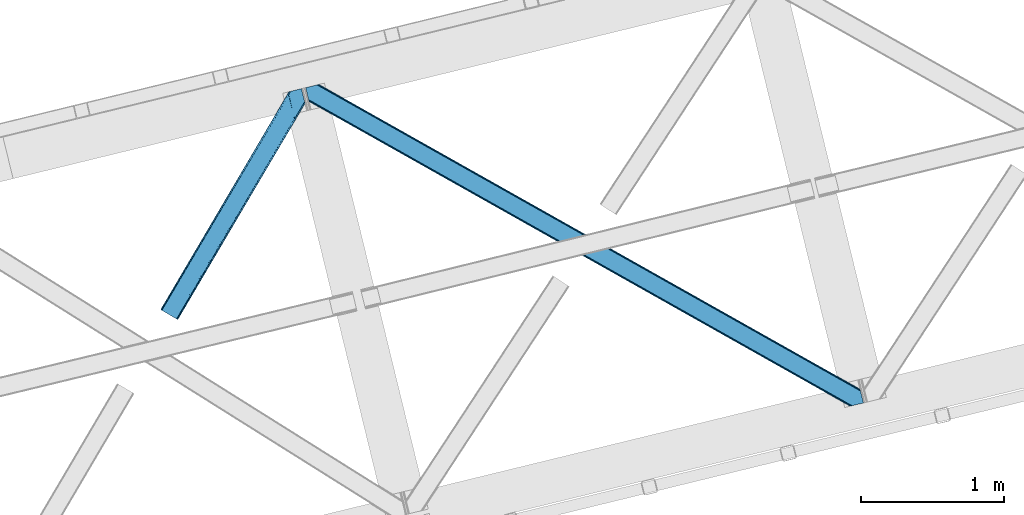
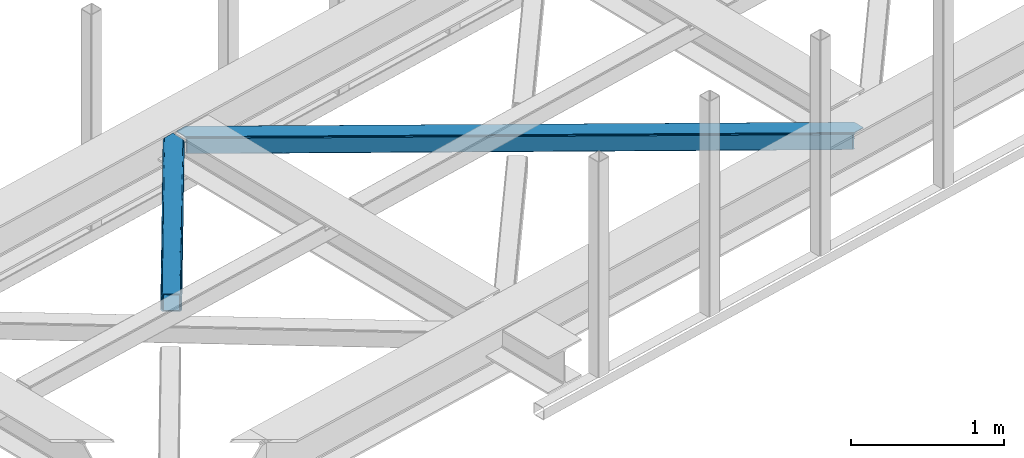
# One storey, part 26 of 67: 2 members.
"""IFC4 building model written with IfcOpenShell, lengths in millimetres."""

from ifc_helpers import new_model, entity, si_unit, converted_unit, derived_unit, direction, frame, origin, place, context, subcontext, project, spatial, triangles, type_object, element, save


model = new_model("IFC4")

# Units and contexts
model_context = context("Model", 3, precision=0.01, world=origin(), true_north=direction((6.12303176911189e-17, 1.0)))
plan_context = context("Plan", 3, precision=0.01, world=origin(), true_north=direction((6.12303176911189e-17, 1.0)))
body_context = subcontext(model_context, "Body", "Model", "MODEL_VIEW")
ifc_project = project(units=[si_unit("LENGTHUNIT", "METRE", prefix="MILLI"), si_unit("AREAUNIT", "SQUARE_METRE"), si_unit("VOLUMEUNIT", "CUBIC_METRE"), converted_unit("PLANEANGLEUNIT", "DEGREE", entity("IfcRatioMeasure", 0.0174532925199433), si_unit("PLANEANGLEUNIT", "RADIAN"), dimensions=[0, 0, 0, 0, 0, 0, 0]), si_unit("MASSUNIT", "GRAM", prefix="KILO"), derived_unit("MASSDENSITYUNIT", [(si_unit("MASSUNIT", "GRAM", prefix="KILO"), 1), (si_unit("LENGTHUNIT", "METRE"), -3)]), derived_unit("MOMENTOFINERTIAUNIT", [(si_unit("LENGTHUNIT", "METRE"), 4)]), si_unit("TIMEUNIT", "SECOND"), si_unit("FREQUENCYUNIT", "HERTZ"), si_unit("THERMODYNAMICTEMPERATUREUNIT", "DEGREE_CELSIUS"), derived_unit("THERMALTRANSMITTANCEUNIT", [(si_unit("MASSUNIT", "GRAM", prefix="KILO"), 1), (si_unit("THERMODYNAMICTEMPERATUREUNIT", "KELVIN"), -1), (si_unit("TIMEUNIT", "SECOND"), -3)]), derived_unit("VOLUMETRICFLOWRATEUNIT", [(si_unit("LENGTHUNIT", "METRE"), 3), (si_unit("TIMEUNIT", "SECOND"), -1)]), derived_unit("MASSFLOWRATEUNIT", [(si_unit("MASSUNIT", "GRAM", prefix="KILO"), 1), (si_unit("TIMEUNIT", "SECOND"), -1)]), derived_unit("ROTATIONALFREQUENCYUNIT", [(si_unit("TIMEUNIT", "SECOND"), -1)]), si_unit("ELECTRICCURRENTUNIT", "AMPERE"), si_unit("ELECTRICVOLTAGEUNIT", "VOLT"), si_unit("POWERUNIT", "WATT"), si_unit("FORCEUNIT", "NEWTON", prefix="KILO"), si_unit("ILLUMINANCEUNIT", "LUX"), si_unit("LUMINOUSFLUXUNIT", "LUMEN"), si_unit("LUMINOUSINTENSITYUNIT", "CANDELA"), derived_unit("USERDEFINED", [(si_unit("MASSUNIT", "GRAM", prefix="KILO"), -1), (si_unit("LENGTHUNIT", "METRE"), -2), (si_unit("TIMEUNIT", "SECOND"), 3), (si_unit("LUMINOUSFLUXUNIT", "LUMEN"), 1)]), derived_unit("LINEARVELOCITYUNIT", [(si_unit("LENGTHUNIT", "METRE"), 1), (si_unit("TIMEUNIT", "SECOND"), -1)]), si_unit("PRESSUREUNIT", "PASCAL"), derived_unit("USERDEFINED", [(si_unit("LENGTHUNIT", "METRE"), -2), (si_unit("MASSUNIT", "GRAM", prefix="KILO"), 1), (si_unit("TIMEUNIT", "SECOND"), -2)]), derived_unit("LINEARFORCEUNIT", [(si_unit("MASSUNIT", "GRAM", prefix="KILO"), 1), (si_unit("LENGTHUNIT", "METRE"), 1), (si_unit("TIMEUNIT", "SECOND"), -2), (si_unit("LENGTHUNIT", "METRE"), -1)]), derived_unit("PLANARFORCEUNIT", [(si_unit("MASSUNIT", "GRAM", prefix="KILO"), 1), (si_unit("LENGTHUNIT", "METRE"), 1), (si_unit("TIMEUNIT", "SECOND"), -2), (si_unit("LENGTHUNIT", "METRE"), -2)])], contexts=[model_context, plan_context])

# Site, building, storey
site_placement = place(None, origin())
site = spatial("IfcSite", under=ifc_project, at=site_placement, CompositionType="ELEMENT")
building_placement = place(site_placement, origin())
building = spatial("IfcBuilding", under=site, at=building_placement, CompositionType="ELEMENT")
storey_placement = place(building_placement, frame((0.0, 0.0, 19800.0)))
storey = spatial("IfcBuildingStorey", under=building, at=storey_placement, CompositionType="ELEMENT", Elevation=19800.0)

# Members
member_type_1 = type_object("IfcMemberType", PredefinedType="BRACE")
member_1_placement = place(storey_placement, frame((-49332.8771484375, 6520.94441070557, 3823.99987792968)))
element("IfcMember", 1, at=member_1_placement, inside=storey, type_object=member_type_1, ObjectType="Steel Horizontal Brace", PredefinedType="BRACE", context=body_context, shape_type="Tessellation", body=[
    triangles([(3809.33957519531, 0.0, 122.499499511719), (3811.23713378907, 0.462181091308594, 129.196765136719), (23.4590332031294, 2133.5476776123, 129.196765136719), (23.8915649414048, 2131.77569274902, 122.499499511719), (3816.63215332032, 1.7772171020506, 134.87548828125), (22.2265502929731, 2138.59446258545, 134.87548828125), (3824.70607910156, 3.74512023925763, 138.668280029298), (20.3894531250044, 2146.14690856934, 138.668280029298), (3834.23107910156, 6.06707153320258, 140.00075683594), (18.2174926757798, 2155.05566711426, 140.00075683594), (1916.9806640625, 1065.68146362305, 17.5012573242202), (2556.1183959961, 705.752851867675, 17.5012573242202), (3195.25147705078, 345.824240112304, 17.5012573242202), (3809.33957519531, 0.0, 17.5012573242202), (1277.84758300782, 1425.61065673828, 17.5012573242202), (638.709851074222, 1785.53868713379, 17.5012573242202), (23.8915649414048, 2131.77569274902, 17.5012573242202), (3885.46051025391, 97.721360778808, 140.00075683594), (3903.67800292969, 22.9951080322262, 140.00075683594), (69.4469238281235, 2246.70995635986, 140.00075683594), (0.0, 2229.78191986084, 140.00075683594), (3883.28854980469, 106.63011932373, 138.668280029298), (78.971923828125, 2249.03190765381, 138.668280029298), (3881.44680175781, 114.182565307617, 134.87548828125), (87.0458496093779, 2251.00039215088, 134.87548828125), (3880.21896972656, 119.229350280762, 129.196765136719), (92.4408691406279, 2252.31542816162, 129.196765136719), (3879.78643798828, 121.001335144043, 122.499499511719), (94.3384277343794, 2252.77760925293, 122.499499511719), (3265.41928710938, 466.982542419433, 17.5012573242202), (3879.78643798828, 121.001335144043, 17.5012573242202), (2626.2955078125, 826.905340576172, 17.5012573242202), (1987.17172851563, 1186.82813873291, 17.5012573242202), (708.924169921876, 1906.67315368652, 17.5012573242202), (94.3384277343794, 2252.77760925293, 17.5012573242202), (1348.04794921875, 1546.75093688965, 17.5012573242202), (77.0929687500029, 2248.57321472168, 127.873590087893), (69.0143920898481, 2246.60473022461, 131.668707275392), (82.4879882812529, 2249.88883209228, 122.197192382813), (59.4893920898467, 2244.28277893066, 133.001184082033), (0.0, 2229.78191986084, 133.001184082033), (84.3808959960952, 2250.35043182373, 115.499926757813), (84.3808959960952, 2250.35043182373, 24.5008300781265), (82.4879882812529, 2249.88883209228, 17.8035644531265), (92.0548461914077, 2252.22124786377, 10.8691040039084), (91.5851074218735, 2252.10613861084, 9.49942016601563), (77.0929687500029, 2248.57321472168, 12.1248413085959), (72.3118652343765, 2247.40816955566, 9.49942016601563), (1983.48823242188, 1180.86745605469, 24.5008300781265), (3882.05606689453, 111.689694213866, 115.499926757813), (2626.78850097657, 818.593057250976, 24.5008300781265), (3270.08876953125, 456.319239807129, 24.5008300781265), (3882.05606689453, 111.689694213866, 24.5008300781265), (1340.18796386719, 1543.14127349854, 24.5008300781265), (696.892346191409, 1905.41509094238, 24.5008300781265), (3882.48859863282, 109.917127990722, 122.197192382813), (3883.71643066406, 104.870924377441, 127.873590087893), (3885.55817871094, 97.318478393554, 131.668707275392), (3887.73013916016, 88.4097198486324, 133.001184082033), (3883.71643066406, 104.870924377441, 12.1248413085959), (3885.41865234375, 97.8998382568352, 8.52041015625218), (3880.59104003906, 117.702699279785, 8.52041015625218), (3903.67800292969, 22.9951080322262, 133.001184082033), (3882.48859863282, 109.917127990722, 17.8035644531265), (3880.37244873047, 118.590435791015, 10.9365417480476), (3844.18861083985, 8.4942489624018, 133.001184082033), (15.9478637695356, 2164.3678894043, 133.001184082033), (3834.66361083985, 6.17229766845685, 131.668707275392), (18.1198242187529, 2155.45854949951, 131.668707275392), (3826.58503417969, 4.20381317138617, 127.873590087893), (19.9569213867217, 2147.90610351563, 127.873590087893), (3821.19001464844, 2.88877716064417, 122.197192382813), (21.1894042968779, 2142.85989990234, 122.197192382813), (3819.2971069336, 2.42717742919922, 115.499926757813), (21.6219360351606, 2141.08791503906, 115.499926757813), (3208.50183105469, 346.39571685791, 24.5008300781265), (3819.2971069336, 2.42717742919922, 24.5008300781265), (2565.16435546875, 708.690463256836, 24.5008300781265), (1921.82687988281, 1070.98520965576, 24.5008300781265), (635.156579589842, 1795.57528381348, 24.5008300781265), (21.6219360351606, 2141.08791503906, 24.5008300781265), (1278.49405517578, 1433.28053741455, 24.5008300781265), (21.1894042968779, 2142.85989990234, 17.8035644531265), (19.9569213867217, 2147.90610351563, 12.1248413085959), (23.263696289061, 2134.3505355835, 9.49942016601563), (23.3706665039063, 2133.90986480713, 10.8691040039084), (18.8686157226548, 2152.37676086426, 9.49942016601563), (3821.19001464844, 2.88877716064417, 17.8035644531265), (3811.91616210937, 0.628450012206486, 10.9365417480476), (3812.86494140625, 0.859831237792605, 8.52041015625218), (3826.58503417969, 4.20381317138617, 12.1248413085959), (3834.04039306641, 6.02056274414008, 8.52041015625218), (190.667431640628, 2055.62743377685, 9.49942016601563), (195.062512207034, 2037.60120849609, 9.49942016601563), (196.076403808598, 2037.6692276001, 8.49948120117188), (196.057800292969, 2037.42389373779, 8.8831787109375), (191.290649414063, 2056.67097473144, 8.85294799804615), (195.732238769531, 2037.48144836426, 9.08316650390771), (191.346459960936, 2055.82567749023, 9.20641479492406), (195.388073730472, 2037.54365386963, 9.29943237304906), (191.006945800786, 2055.72684631348, 9.35291748046802), (191.239489746098, 2057.51627197266, 8.49948120117188), (150.921020507813, 2218.69073638916, 9.49942016601563), (155.316101074219, 2200.6645111084, 9.49942016601563), (151.251232910159, 2218.34947814941, 9.25757446289208), (155.813745117186, 2200.23721160889, 9.42500610351635), (151.60469970703, 2217.98496551514, 8.99945068359375), (156.250927734378, 2199.30529174805, 9.11804809570458), (151.962817382817, 2217.619871521, 8.74132690429906), (156.692761230472, 2198.36407012939, 8.80643920898365), (152.293029785156, 2217.27861328125, 8.49948120117188), (157.129943847656, 2197.43156890869, 8.49948120117188), (3713.61983642578, 194.649165344238, 8.52041015625218), (3708.7922241211, 214.452026367188, 8.52041015625218), (3713.26636962891, 194.529986572265, 8.40181274414135), (3708.39689941407, 214.570623779297, 8.37390747070458), (3713.06173095703, 194.460223388672, 8.3320495605476), (3708.00622558594, 214.689221191406, 8.22740478515698), (3707.90390625, 214.477606201172, 7.87393798828271), (3713.112890625, 193.949789428711, 8.19484863281468), (3707.80623779297, 214.265991210938, 7.52047119140843), (3713.23846435547, 192.705679321289, 7.85765991211156), (3713.36403808594, 191.465057373047, 7.52047119140843), (3264.76351318359, 465.821566772461, 10.8039916992202), (3262.90316162109, 462.516535949707, 5.12526855468968), (3260.11728515625, 457.569744873046, 1.33247680664135), (3708.58293457032, 211.088278198242, 5.59500732422021), (708.268395996092, 1905.51275939941, 10.8039916992202), (706.408044433592, 1902.2071472168, 5.12526855468968), (153.148791503911, 2213.77475738525, 5.12526855468968), (703.622167968751, 1897.26035614014, 1.33247680664135), (154.990539550781, 2206.22231140137, 1.33247680664135), (700.333996582034, 1891.42524719238, 0.0), (157.162499999999, 2197.31355285644, 0.0), (3710.29445800781, 204.051498413086, 1.33247680664135), (3712.46641845704, 195.142739868164, 0.0), (3256.83376464844, 451.73405456543, 0.0), (2625.63973388672, 825.744364929199, 10.8039916992202), (1986.51595458984, 1185.66716308594, 10.8039916992202), (1347.39217529297, 1545.58996124268, 10.8039916992202), (2623.77938232422, 822.439334106445, 5.12526855468968), (1984.65560302734, 1182.36213226318, 5.12526855468968), (1345.53182373047, 1542.28434906006, 5.12526855468968), (2620.99350585938, 817.492543029785, 1.33247680664135), (1981.8697265625, 1177.41475982666, 1.33247680664135), (1342.74594726563, 1537.3375579834, 1.33247680664135), (2617.70998535156, 811.656852722168, 0.0), (1978.58155517578, 1171.57965087891, 0.0), (1339.45777587891, 1531.50244903564, 0.0), (3746.51550292969, 55.4634750366204, 0.0), (3203.83699951172, 361.072146606445, 0.0), (2564.70391845703, 721.000758361816, 0.0), (1925.57083740235, 1080.92995147705, 0.0), (1286.43310546875, 1440.85856323242, 0.0), (647.300024414064, 1800.78717498779, 0.0), (191.206933593749, 2057.6342880249, 0.0), (3195.90725097656, 346.984634399414, 10.8039916992202), (639.365624999999, 1786.69966278076, 10.8039916992202), (641.225976562499, 1790.00527496338, 5.12526855468968), (195.220642089844, 2041.17308349609, 5.12526855468968), (3197.76760253906, 350.290246582031, 5.12526855468968), (3200.55347900391, 355.237037658691, 1.33247680664135), (3748.6874633789, 46.5547164916989, 1.33247680664135), (3752.58024902344, 34.8100845336912, 8.52041015625218), (3750.40363769532, 39.517936706543, 5.59500732422021), (3751.18033447266, 36.3402236938473, 7.52047119140843), (3752.24073486328, 35.1804107666012, 8.278564453125), (644.011853027347, 1794.95206604004, 1.33247680664135), (193.378894042973, 2048.72552947998, 1.33247680664135), (2561.41574707031, 715.165649414063, 1.33247680664135), (1922.28266601563, 1075.09426116943, 1.33247680664135), (1283.14958496094, 1435.02345428467, 1.33247680664135), (2558.62987060547, 710.218858337402, 5.12526855468968), (1919.49678955078, 1070.14747009277, 5.12526855468968), (1280.36370849609, 1430.07666320801, 5.12526855468968), (2556.76951904297, 706.913246154785, 10.8039916992202), (1917.63643798828, 1066.84243927002, 10.8039916992202), (1278.49870605469, 1426.77105102539, 10.8039916992202), (3745.61788330078, 59.1411575317379, 7.52047119140843), (3746.13413085938, 57.3430114746088, 7.90416870117406), (3746.6736328125, 56.4360900878901, 8.10880737304615), (3747.30150146485, 55.3762710571282, 8.34832763671875), (3747.75263671875, 54.6129455566406, 8.52041015625218), (3211.01795654297, 350.861723327636, 12.1248413085959), (3217.08735351563, 361.644204711914, 6.99957275390625), (3213.80383300781, 355.808514404296, 8.3320495605476), (3744.24587402344, 64.7751159667969, 6.99957275390625), (643.742102050783, 1810.82377166748, 6.99957275390625), (188.937304687504, 2066.94651031494, 6.99957275390625), (637.672705078126, 1800.0412902832, 12.1248413085959), (640.458581542967, 1804.98866271973, 8.3320495605476), (635.807702636717, 1796.73625946045, 17.8035644531265), (3209.15760498047, 347.556111145019, 17.8035644531265), (2565.82012939453, 709.851438903808, 17.8035644531265), (1922.4826538086, 1072.14618530273, 17.8035644531265), (1279.14517822266, 1434.44093170166, 17.8035644531265), (2567.68048095703, 713.156469726562, 12.1248413085959), (1924.3430053711, 1075.45179748535, 12.1248413085959), (1281.00552978516, 1437.74654388428, 12.1248413085959), (2570.46635742188, 718.103842163086, 8.3320495605476), (1927.12888183594, 1080.39858856201, 8.3320495605476), (1283.79140625, 1442.69333496094, 8.3320495605476), (2573.7545288086, 723.938951110839, 6.99957275390625), (1930.41705322266, 1086.23369750977, 6.99957275390625), (1287.07957763672, 1448.52902526855, 6.99957275390625), (694.376220703125, 1900.94908447266, 12.1248413085959), (691.590344238284, 1896.002293396, 8.3320495605476), (157.264819335942, 2196.88450927734, 8.41343994140698), (159.43212890625, 2188.00191192627, 6.99957275390625), (3261.50324707032, 441.070751953124, 6.99957275390625), (3264.78676757812, 446.905860900879, 8.3320495605476), (3714.73604736328, 185.831098937988, 6.99957275390625), (3267.57264404297, 451.853233337402, 12.1248413085959), (688.302172851567, 1890.16718444824, 6.99957275390625), (696.236572265625, 1904.25469665527, 17.8035644531265), (3269.43299560547, 455.158264160156, 17.8035644531265), (2618.20297851563, 803.344569396972, 6.99957275390625), (2621.48649902344, 809.179678344726, 8.3320495605476), (1978.18623046875, 1171.45407714844, 8.3320495605476), (1974.90270996094, 1165.61896820068, 6.99957275390625), (1334.89061279297, 1533.72847595215, 8.3320495605476), (1331.60244140625, 1527.89336700439, 6.99957275390625), (2624.27237548828, 814.12705078125, 12.1248413085959), (1980.9767578125, 1176.40144958496, 12.1248413085959), (1337.67648925781, 1538.67526702881, 12.1248413085959), (2626.13272705078, 817.432081604004, 17.8035644531265), (1982.837109375, 1179.70648040771, 17.8035644531265), (1339.53684082031, 1541.98087921143, 17.8035644531265)], [[1, 2, 3], [3, 4, 1], [2, 5, 6], [6, 3, 2], [5, 7, 8], [8, 6, 5], [7, 9, 10], [10, 8, 7], [11, 1, 4], [1, 12, 13], [11, 12, 1], [13, 14, 1], [15, 4, 16], [4, 15, 11], [17, 16, 4], [9, 18, 10], [9, 19, 18], [20, 10, 18], [21, 10, 20], [18, 22, 23], [23, 20, 18], [22, 24, 25], [25, 23, 22], [24, 26, 27], [27, 25, 24], [26, 28, 29], [29, 27, 26], [30, 28, 31], [28, 30, 32], [28, 33, 29], [33, 28, 32], [34, 35, 29], [36, 29, 33], [29, 36, 34], [37, 38, 23], [25, 37, 23], [25, 27, 39], [37, 25, 39], [39, 27, 29], [38, 20, 23], [21, 40, 41], [21, 20, 40], [38, 40, 20], [39, 29, 42], [43, 35, 44], [29, 43, 42], [35, 45, 44], [29, 35, 43], [46, 44, 45], [47, 44, 46], [48, 47, 46], [49, 50, 42], [50, 51, 52], [49, 51, 50], [52, 53, 50], [54, 42, 55], [42, 54, 49], [43, 55, 42], [50, 56, 42], [39, 42, 56], [56, 57, 39], [37, 39, 57], [57, 58, 37], [38, 37, 58], [58, 59, 38], [40, 38, 59], [57, 24, 22], [60, 61, 62], [24, 57, 56], [58, 57, 22], [58, 18, 59], [19, 59, 18], [59, 19, 63], [58, 22, 18], [31, 28, 53], [62, 64, 60], [64, 31, 53], [65, 64, 62], [65, 31, 64], [28, 50, 53], [56, 26, 24], [28, 26, 56], [50, 28, 56], [59, 66, 67], [66, 59, 63], [67, 40, 59], [41, 40, 67], [66, 68, 67], [69, 67, 68], [68, 70, 69], [71, 69, 70], [70, 72, 71], [73, 71, 72], [72, 74, 73], [75, 73, 74], [76, 74, 77], [74, 76, 78], [74, 79, 75], [79, 74, 78], [80, 81, 75], [82, 75, 79], [75, 82, 80], [73, 6, 71], [75, 81, 4], [3, 73, 4], [73, 3, 6], [73, 75, 4], [81, 17, 4], [83, 84, 85], [85, 86, 83], [86, 17, 83], [81, 83, 17], [67, 10, 21], [10, 69, 8], [69, 10, 67], [21, 41, 67], [69, 71, 8], [87, 85, 84], [8, 71, 6], [70, 68, 7], [5, 70, 7], [5, 2, 72], [70, 5, 72], [72, 2, 1], [68, 9, 7], [19, 66, 63], [19, 9, 66], [68, 66, 9], [72, 1, 74], [77, 14, 88], [1, 77, 74], [14, 89, 88], [1, 14, 77], [90, 88, 89], [91, 88, 90], [92, 91, 90], [93, 94, 85], [85, 87, 93], [95, 96, 97], [96, 98, 99], [99, 98, 100], [101, 100, 94], [94, 93, 101], [100, 101, 99], [99, 97, 96], [97, 102, 95], [103, 104, 46], [48, 46, 104], [105, 106, 104], [107, 108, 106], [109, 110, 108], [111, 112, 110], [110, 109, 111], [108, 107, 109], [106, 105, 107], [104, 103, 105], [62, 61, 113], [113, 114, 62], [115, 116, 114], [117, 118, 116], [116, 115, 117], [119, 118, 120], [121, 119, 122], [122, 123, 121], [120, 122, 119], [117, 120, 118], [114, 113, 115], [124, 30, 31], [125, 124, 118], [118, 119, 125], [119, 121, 125], [124, 65, 114], [114, 116, 124], [116, 118, 124], [65, 62, 114], [126, 125, 127], [45, 128, 103], [128, 129, 130], [130, 111, 128], [128, 109, 107], [109, 128, 111], [128, 105, 103], [105, 128, 107], [128, 45, 35], [35, 34, 128], [103, 46, 45], [129, 131, 132], [132, 130, 129], [131, 133, 134], [134, 132, 131], [135, 136, 137], [137, 126, 135], [127, 135, 126], [121, 127, 125], [31, 65, 124], [30, 124, 138], [138, 32, 30], [32, 138, 139], [139, 33, 32], [33, 139, 36], [140, 36, 139], [36, 140, 34], [128, 34, 140], [124, 125, 138], [141, 138, 125], [138, 141, 139], [142, 139, 141], [139, 142, 143], [143, 140, 139], [140, 143, 129], [129, 128, 140], [125, 126, 144], [144, 141, 125], [141, 144, 145], [145, 142, 141], [142, 145, 143], [146, 143, 145], [143, 146, 129], [131, 129, 146], [126, 137, 147], [147, 144, 126], [144, 147, 148], [148, 145, 144], [145, 148, 149], [149, 146, 145], [146, 149, 131], [133, 131, 149], [136, 150, 151], [137, 151, 147], [151, 137, 136], [148, 152, 153], [152, 147, 151], [148, 147, 152], [133, 149, 154], [153, 149, 148], [149, 153, 154], [155, 133, 154], [156, 133, 155], [134, 133, 156], [157, 89, 14], [158, 16, 17], [159, 96, 95], [158, 86, 94], [94, 159, 158], [94, 98, 159], [86, 85, 94], [95, 160, 159], [161, 162, 163], [89, 157, 164], [157, 161, 165], [165, 166, 157], [167, 164, 157], [157, 166, 167], [164, 90, 89], [163, 165, 161], [150, 163, 162], [162, 151, 150], [155, 168, 169], [169, 156, 155], [168, 159, 160], [160, 169, 168], [17, 86, 158], [14, 13, 157], [151, 162, 170], [170, 152, 151], [152, 170, 153], [171, 153, 170], [153, 171, 154], [172, 154, 171], [154, 172, 155], [168, 155, 172], [162, 161, 170], [173, 170, 161], [170, 173, 171], [174, 171, 173], [171, 174, 172], [175, 172, 174], [172, 175, 168], [159, 168, 175], [161, 157, 176], [176, 173, 161], [173, 176, 177], [177, 174, 173], [174, 177, 178], [178, 175, 174], [175, 178, 158], [158, 159, 175], [157, 13, 176], [12, 176, 13], [176, 12, 177], [11, 177, 12], [177, 11, 178], [15, 178, 11], [178, 15, 158], [16, 158, 15], [166, 179, 180], [166, 180, 181], [167, 181, 182], [167, 182, 183], [92, 90, 183], [164, 183, 90], [184, 183, 182], [91, 92, 183], [183, 184, 91], [185, 180, 179], [182, 185, 186], [182, 181, 185], [180, 185, 181], [179, 187, 185], [188, 189, 102], [93, 84, 190], [93, 87, 84], [102, 190, 191], [190, 102, 97], [97, 99, 190], [80, 192, 81], [83, 81, 192], [192, 190, 83], [84, 83, 190], [102, 191, 188], [182, 186, 184], [88, 91, 184], [184, 193, 88], [77, 88, 193], [193, 76, 77], [76, 193, 194], [194, 78, 76], [78, 194, 79], [195, 79, 194], [79, 195, 82], [196, 82, 195], [82, 196, 192], [192, 80, 82], [193, 184, 194], [197, 194, 184], [194, 197, 195], [198, 195, 197], [195, 198, 199], [199, 196, 195], [196, 199, 190], [190, 192, 196], [184, 186, 200], [200, 197, 184], [197, 200, 201], [201, 198, 197], [198, 201, 202], [202, 199, 198], [199, 202, 191], [191, 190, 199], [186, 185, 203], [203, 200, 186], [200, 203, 201], [204, 201, 203], [201, 204, 202], [205, 202, 204], [202, 205, 191], [188, 191, 205], [206, 106, 108], [108, 207, 206], [108, 110, 207], [110, 208, 207], [104, 206, 47], [47, 48, 104], [207, 208, 209], [210, 123, 122], [122, 211, 210], [122, 117, 211], [210, 212, 123], [213, 211, 117], [61, 60, 113], [213, 113, 60], [209, 214, 207], [206, 215, 44], [44, 47, 206], [215, 55, 43], [43, 44, 215], [64, 53, 216], [52, 216, 53], [60, 64, 213], [216, 213, 64], [210, 211, 217], [218, 217, 211], [217, 218, 219], [219, 220, 217], [220, 219, 221], [221, 222, 220], [222, 221, 207], [207, 214, 222], [211, 213, 223], [223, 218, 211], [218, 223, 224], [224, 219, 218], [219, 224, 221], [225, 221, 224], [221, 225, 207], [206, 207, 225], [213, 216, 223], [226, 223, 216], [223, 226, 224], [227, 224, 226], [224, 227, 225], [228, 225, 227], [225, 228, 215], [215, 206, 225], [216, 52, 51], [51, 226, 216], [226, 51, 227], [49, 227, 51], [227, 49, 228], [54, 228, 49], [228, 54, 215], [55, 215, 54], [209, 134, 189], [132, 208, 130], [208, 132, 134], [130, 208, 111], [134, 209, 208], [189, 134, 156], [169, 102, 156], [102, 169, 160], [156, 102, 189], [160, 95, 102], [136, 212, 187], [123, 127, 121], [136, 123, 212], [123, 135, 127], [123, 136, 135], [150, 136, 187], [179, 150, 187], [165, 179, 166], [179, 163, 150], [179, 165, 163], [203, 185, 210], [210, 217, 203], [217, 204, 203], [204, 217, 220], [185, 212, 210], [185, 187, 212], [214, 188, 222], [188, 214, 189], [209, 189, 214], [205, 222, 188], [220, 205, 204], [222, 205, 220]]),
])
member_type_2 = type_object("IfcMemberType", PredefinedType="BRACE")
member_2_placement = place(storey_placement, frame((-50348.2756347656, 7126.42373199463, 3823.99987792968)))
element("IfcMember", 2, at=member_2_placement, inside=storey, type_object=member_type_2, ObjectType="Steel Horizontal Brace", PredefinedType="BRACE", context=body_context, shape_type="Tessellation", body=[
    triangles([(105.565649414064, 8.87852783203198, 0.0), (15.0828002929702, 62.1485321044929, 0.0), (892.847827148435, 1346.13992614746, 0.0), (857.170935058595, 1492.50308532715, 0.0), (854.896655273435, 1501.83798065186, 1.33247680664135), (9.31105957031104, 65.5459991455082, 1.33247680664135), (852.966540527341, 1509.7520324707, 5.12526855468968), (4.4183349609375, 68.4266372680668, 5.12526855468968), (851.678247070311, 1515.03950042725, 10.8039916992202), (1.14876708984229, 70.3509384155277, 10.8039916992202), (851.222460937497, 1516.89636383057, 17.5012573242202), (0.0, 71.027059936524, 17.5012573242202), (893.638476562497, 1342.89826354981, 0.155804443358647), (111.337390136716, 5.48106079101581, 1.33247680664135), (899.559045410155, 1344.34178009033, 1.33247680664135), (912.390820312496, 1347.47007751465, 10.8039916992202), (914.195361328122, 1347.90958557129, 17.5012573242202), (120.643798828125, 0.0, 17.5012573242202), (119.499682617185, 0.676121520996276, 10.8039916992202), (907.251599121089, 1346.21724700928, 5.12526855468968), (116.230114746089, 2.60042266845721, 5.12526855468968), (902.498400878903, 1345.05743408203, 17.9802978515618), (893.638476562497, 1342.89826354981, 9.69243164062573), (897.768457031249, 1343.90517883301, 12.1248413085959), (903.726232910158, 1345.35683441162, 19.5011352539077), (914.195361328122, 1347.90958557129, 19.5011352539077), (1011.61732177734, 1513.38669433594, 19.5011352539077), (1008.98957519531, 1524.16103668213, 19.5011352539077), (1011.61732177734, 1513.38669433594, 122.499499511719), (120.643798828125, 0.0, 122.499499511719), (114.61160888672, 3.5515274047857, 24.5008300781265), (1009.24072265625, 1523.14423828125, 24.5008300781265), (113.462841796871, 4.22706756591833, 17.8035644531265), (110.197924804685, 6.15195007324292, 12.1248413085959), (105.305200195311, 9.03200683593786, 8.3320495605476), (99.5334594726519, 12.4294738769531, 6.99957275390625), (892.685046386716, 1346.80035095215, 8.8831787109375), (890.471228027345, 1355.89747009277, 6.99957275390625), (21.114990234375, 58.5975860595709, 6.99957275390625), (859.547534179685, 1482.74496002197, 6.99957275390625), (853.961828613283, 1505.66042175293, 18.501196289064), (851.222460937497, 1516.89636383057, 18.501196289064), (854.096704101561, 1505.10929260254, 17.8803039550803), (855.343139648438, 1499.99448852539, 12.1248413085959), (857.273254394531, 1492.08043670654, 8.3320495605476), (1009.24072265625, 1523.14423828125, 115.499926757813), (114.61160888672, 3.5515274047857, 115.499926757813), (1008.78493652344, 1525.00110168457, 122.197192382813), (113.462841796871, 4.22706756591833, 122.197192382813), (1007.49664306641, 1530.28915100098, 127.873590087893), (110.197924804685, 6.15195007324292, 127.873590087893), (1005.57117919921, 1538.20320281983, 131.668707275392), (105.305200195311, 9.03200683593786, 131.668707275392), (1003.29224853515, 1547.53809814453, 133.001184082033), (99.5334594726519, 12.4294738769531, 133.001184082033), (851.952648925777, 1518.13291625977, 19.5011352539077), (854.580395507808, 1507.35857391358, 19.5011352539077), (851.780566406247, 1517.84049224854, 19.2639404296897), (854.43156738281, 1506.95045928955, 19.2592895507805), (851.589880371095, 1517.5149307251, 19.0011657714858), (854.268786621091, 1506.50978851318, 19.0011657714858), (851.394543457027, 1517.1887878418, 18.7360656738274), (854.110656738281, 1506.06853637695, 18.7407165527366), (908.014343261719, 1598.12687072754, 19.5011352539077), (897.545214843747, 1595.57411956787, 19.5011352539077), (1011.16618652343, 1515.24355773926, 129.196765136719), (1009.8778930664, 1520.53160705566, 134.87548828125), (1008.43146972656, 1526.45624542236, 138.000878906252), (986.311889648438, 1617.21175231934, 138.000878906252), (986.311889648438, 1617.21175231934, 133.001184082033), (897.545214843747, 1595.57411956787, 122.499499511719), (0.0, 71.027059936524, 122.499499511719), (7.18095703124709, 66.7999923706057, 17.8035644531265), (10.4505249023423, 64.875109863282, 12.1248413085959), (6.03218994140479, 67.4755325317383, 24.5008300781265), (907.028356933595, 1597.88560638428, 24.5008300781265), (15.3432495117158, 61.9950531005861, 8.3320495605476), (908.832897949214, 1598.32569580078, 122.197192382813), (899.349755859374, 1596.01362762451, 129.196765136719), (904.48897705078, 1597.26645812988, 134.87548828125), (930.738537597652, 1603.66548614502, 133.001184082033), (910.246765136719, 1598.67044219971, 138.000878906252), (921.664672851563, 1601.45341186523, 131.668707275392), (913.972119140621, 1599.57852630615, 127.873590087893), (907.028356933595, 1597.88560638428, 115.499926757813), (21.114990234375, 58.5975860595709, 133.001184082033), (6.03218994140479, 67.4755325317383, 115.499926757813), (15.3432495117158, 61.9950531005861, 131.668707275392), (10.4505249023423, 64.875109863282, 127.873590087893), (7.18095703124709, 66.7999923706057, 122.197192382813), (119.499682617185, 0.676121520996276, 129.196765136719), (116.230114746089, 2.60042266845721, 134.87548828125), (111.337390136716, 5.48106079101581, 138.668280029298), (105.565649414064, 8.87852783203198, 140.00075683594), (15.0828002929702, 62.1485321044929, 140.00075683594), (9.31105957031104, 65.5459991455082, 138.668280029298), (4.4183349609375, 68.4266372680668, 134.87548828125), (1.14876708984229, 70.3509384155277, 129.196765136719), (896.991760253906, 1576.15611877441, 138.000878906252), (938.18924560547, 1407.14434204102, 138.000878906252), (899.024194335936, 1563.59525756836, 140.00075683594), (897.042919921871, 1571.7232498169, 139.000817871096), (896.801074218747, 1573.1371170044, 138.638049316407), (896.926647949214, 1575.15443572998, 138.212493896484), (896.86153564453, 1574.14170684815, 138.426434326171), (937.477661132813, 1407.08620605469, 138.293884277344), (937.082336425781, 1408.09544677734, 138.647351074218), (936.682360839841, 1409.1046875, 139.000817871096), (934.701086425783, 1417.23267974854, 140.00075683594)], [[1, 2, 3], [4, 3, 2], [5, 4, 6], [2, 6, 4], [7, 5, 8], [6, 8, 5], [9, 7, 10], [8, 10, 7], [11, 9, 12], [10, 12, 9], [1, 3, 13], [13, 14, 1], [13, 15, 14], [16, 17, 18], [18, 19, 16], [20, 16, 19], [19, 21, 20], [15, 20, 21], [21, 14, 15], [20, 22, 16], [23, 24, 15], [23, 15, 13], [15, 24, 20], [16, 25, 17], [20, 24, 22], [16, 22, 25], [26, 17, 25], [26, 25, 27], [28, 27, 25], [27, 29, 26], [30, 26, 29], [26, 18, 17], [30, 18, 26], [31, 32, 25], [25, 33, 31], [25, 22, 33], [32, 28, 25], [33, 22, 24], [34, 24, 23], [23, 35, 34], [36, 35, 37], [37, 38, 36], [23, 37, 35], [24, 34, 33], [39, 36, 38], [38, 40, 39], [9, 11, 41], [11, 42, 41], [43, 9, 41], [43, 7, 9], [44, 7, 43], [5, 44, 45], [44, 5, 7], [4, 5, 45], [45, 40, 4], [37, 23, 13], [37, 3, 38], [3, 40, 38], [40, 3, 4], [37, 13, 3], [46, 32, 31], [31, 47, 46], [48, 46, 49], [47, 49, 46], [50, 48, 51], [49, 51, 48], [52, 50, 53], [51, 53, 50], [54, 52, 55], [53, 55, 52], [56, 57, 58], [59, 58, 57], [58, 59, 60], [61, 60, 59], [60, 61, 62], [63, 62, 61], [62, 63, 42], [41, 42, 63], [57, 56, 64], [65, 64, 56], [66, 48, 67], [46, 29, 27], [27, 32, 46], [32, 27, 28], [48, 29, 46], [66, 29, 48], [50, 68, 67], [52, 68, 50], [67, 48, 50], [52, 54, 68], [54, 69, 68], [70, 69, 54], [71, 60, 62], [58, 60, 71], [71, 56, 58], [56, 71, 65], [42, 12, 72], [12, 42, 11], [71, 42, 72], [42, 71, 62], [73, 74, 44], [75, 73, 43], [43, 41, 75], [43, 57, 75], [64, 76, 57], [75, 57, 76], [44, 43, 73], [45, 44, 74], [74, 77, 45], [40, 45, 77], [77, 39, 40], [78, 79, 80], [81, 82, 69], [69, 70, 81], [81, 83, 82], [84, 82, 83], [80, 82, 84], [78, 71, 79], [85, 71, 78], [80, 84, 78], [65, 76, 64], [85, 65, 71], [76, 65, 85], [86, 54, 55], [54, 86, 81], [70, 54, 81], [76, 85, 87], [87, 75, 76], [83, 81, 86], [86, 88, 83], [84, 83, 88], [88, 89, 84], [78, 84, 89], [89, 90, 78], [85, 78, 90], [90, 87, 85], [91, 51, 49], [47, 18, 30], [91, 49, 30], [91, 92, 51], [49, 47, 30], [51, 92, 93], [55, 94, 95], [94, 53, 93], [53, 94, 55], [53, 51, 93], [19, 34, 21], [31, 18, 47], [18, 33, 19], [33, 18, 31], [19, 33, 34], [1, 36, 2], [14, 21, 34], [34, 35, 14], [35, 36, 1], [1, 14, 35], [89, 96, 97], [95, 86, 55], [95, 88, 86], [88, 95, 96], [89, 88, 96], [87, 72, 12], [98, 90, 89], [97, 98, 89], [90, 98, 72], [87, 90, 72], [6, 74, 8], [2, 36, 39], [39, 77, 2], [77, 74, 6], [6, 2, 77], [10, 8, 74], [12, 75, 87], [73, 12, 10], [12, 73, 75], [73, 10, 74], [99, 68, 82], [99, 100, 68], [68, 69, 82], [96, 95, 101], [101, 102, 96], [97, 96, 103], [104, 97, 105], [104, 99, 97], [97, 103, 105], [82, 80, 99], [97, 99, 80], [102, 103, 96], [79, 71, 98], [72, 98, 71], [80, 79, 97], [98, 97, 79], [92, 67, 100], [100, 93, 92], [67, 68, 100], [106, 107, 93], [94, 93, 107], [107, 108, 94], [108, 109, 94], [66, 67, 92], [92, 91, 66], [29, 66, 91], [91, 30, 29], [95, 94, 109], [109, 101, 95], [107, 103, 102], [105, 103, 107], [106, 104, 105], [100, 99, 104], [107, 106, 105], [102, 108, 107], [102, 101, 109], [109, 108, 102]]),
])

save(model, "model.ifc")
